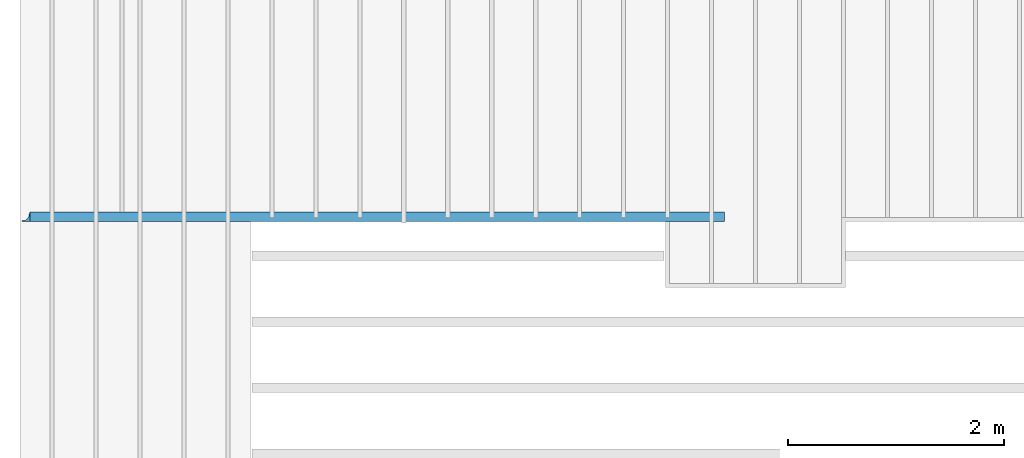
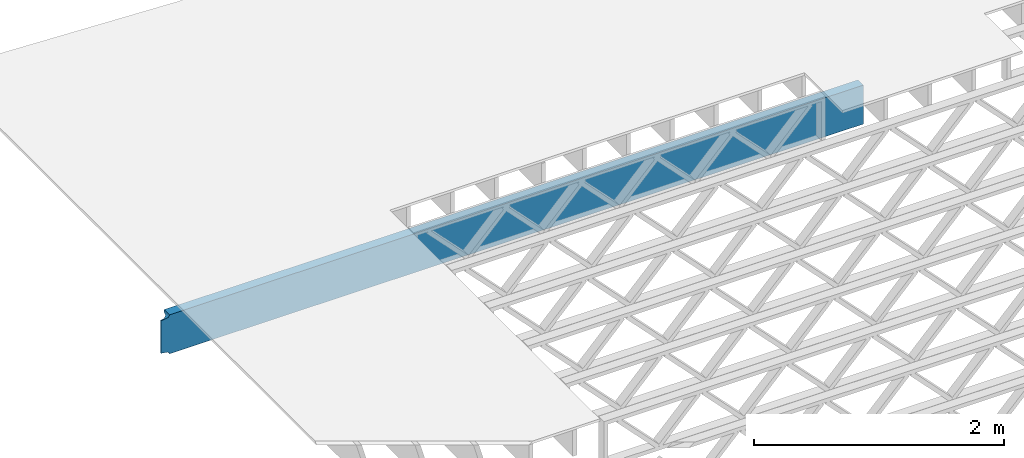
# One storey, part 13 of 23: 1 beam.
"""IFC4 building model written with IfcOpenShell, lengths in feet."""

from ifc_helpers import new_model, entity, si_unit, converted_unit, derived_unit, direction, frame, origin, place, context, subcontext, project, spatial, polyline, circle_curve, parameter, trimmed, segment, composite_curve, outline, source, transform, mapped, material, material_profile, profile_set, type_object, type_shapes, element, save


model = new_model("IFC4")

# Units and contexts
model_context = context("Model", 3, precision=0.0001, world=origin(), true_north=direction((6.12303176911189e-17, 1.0)))
body_context = subcontext(model_context, "Body", "Model", "MODEL_VIEW")
ifc_project = project(units=[converted_unit("LENGTHUNIT", "FOOT", entity("IfcRatioMeasure", 0.3048), si_unit("LENGTHUNIT", "METRE"), dimensions=[1, 0, 0, 0, 0, 0, 0]), converted_unit("AREAUNIT", "SQUARE FOOT", entity("IfcRatioMeasure", 0.09290304), si_unit("AREAUNIT", "SQUARE_METRE"), dimensions=[2, 0, 0, 0, 0, 0, 0]), converted_unit("VOLUMEUNIT", "CUBIC FOOT", entity("IfcRatioMeasure", 0.028316846592), si_unit("VOLUMEUNIT", "CUBIC_METRE"), dimensions=[3, 0, 0, 0, 0, 0, 0]), converted_unit("PLANEANGLEUNIT", "DEGREE", entity("IfcRatioMeasure", 0.0174532925199433), si_unit("PLANEANGLEUNIT", "RADIAN"), dimensions=[0, 0, 0, 0, 0, 0, 0]), si_unit("MASSUNIT", "GRAM", prefix="KILO"), derived_unit("MASSDENSITYUNIT", [(si_unit("MASSUNIT", "GRAM", prefix="KILO"), 1), (si_unit("LENGTHUNIT", "METRE"), -3)]), derived_unit("MOMENTOFINERTIAUNIT", [(si_unit("LENGTHUNIT", "METRE"), 4)]), si_unit("TIMEUNIT", "SECOND"), si_unit("FREQUENCYUNIT", "HERTZ"), si_unit("THERMODYNAMICTEMPERATUREUNIT", "DEGREE_CELSIUS"), derived_unit("THERMALTRANSMITTANCEUNIT", [(si_unit("MASSUNIT", "GRAM", prefix="KILO"), 1), (si_unit("THERMODYNAMICTEMPERATUREUNIT", "KELVIN"), -1), (si_unit("TIMEUNIT", "SECOND"), -3)]), derived_unit("VOLUMETRICFLOWRATEUNIT", [(si_unit("LENGTHUNIT", "METRE"), 3), (si_unit("TIMEUNIT", "SECOND"), -1)]), si_unit("ELECTRICCURRENTUNIT", "AMPERE"), si_unit("ELECTRICVOLTAGEUNIT", "VOLT"), si_unit("POWERUNIT", "WATT"), si_unit("FORCEUNIT", "NEWTON"), si_unit("ILLUMINANCEUNIT", "LUX"), si_unit("LUMINOUSFLUXUNIT", "LUMEN"), si_unit("LUMINOUSINTENSITYUNIT", "CANDELA"), derived_unit("USERDEFINED", [(si_unit("MASSUNIT", "GRAM", prefix="KILO"), -1), (si_unit("LENGTHUNIT", "METRE"), -2), (si_unit("TIMEUNIT", "SECOND"), 3), (si_unit("LUMINOUSFLUXUNIT", "LUMEN"), 1)]), derived_unit("LINEARVELOCITYUNIT", [(si_unit("LENGTHUNIT", "METRE"), 1), (si_unit("TIMEUNIT", "SECOND"), -1)]), si_unit("PRESSUREUNIT", "PASCAL"), derived_unit("USERDEFINED", [(si_unit("LENGTHUNIT", "METRE"), -2), (si_unit("MASSUNIT", "GRAM", prefix="KILO"), 1), (si_unit("TIMEUNIT", "SECOND"), -2)]), derived_unit("LINEARFORCEUNIT", [(si_unit("MASSUNIT", "GRAM", prefix="KILO"), 1), (si_unit("LENGTHUNIT", "METRE"), 1), (si_unit("TIMEUNIT", "SECOND"), -2), (si_unit("LENGTHUNIT", "METRE"), -1)]), derived_unit("PLANARFORCEUNIT", [(si_unit("MASSUNIT", "GRAM", prefix="KILO"), 1), (si_unit("LENGTHUNIT", "METRE"), 1), (si_unit("TIMEUNIT", "SECOND"), -2), (si_unit("LENGTHUNIT", "METRE"), -2)])], contexts=[model_context])

# Site, building, storey
site_placement = place(None, origin())
site = spatial("IfcSite", under=ifc_project, at=site_placement, CompositionType="ELEMENT")
building_placement = place(site_placement, origin())
building = spatial("IfcBuilding", under=site, at=building_placement, CompositionType="ELEMENT")
storey_placement = place(building_placement, frame((0.0, 0.0, 10.8020833333333)))
storey = spatial("IfcBuildingStorey", under=building, at=storey_placement, Name="2ND FLOOR", CompositionType="ELEMENT", Elevation=10.8020833333333)

# Beam
ifc_material = material(Name="STEEL C CHANNEL - HDG - SEE STRUCT", Category="Materials")
ifc_material_profile = material_profile(ifc_material, outline(composite_curve([segment(polyline([(0.0323333333333348, -0.539816380436459, 0.0), (0.0323333333333354, 0.539816380436431, 0.0)]), True, "CONTINUOUS"), segment(polyline([(0.0323333333333354, 0.539816380436431, 0.0), (-0.16349999999999, 0.570833333333319, 0.0)]), True, "CONTINUOUS"), segment(trimmed(circle_curve(frame((-0.16349999999999, 0.624999999999984, 0.0), z_axis=(0.0, 0.0, -1.0), x_axis=(-1.0, 0.0, 0.0)), 0.0541666666666667), [parameter(270.0)], [parameter(359.999999999994)], True, "PARAMETER"), True, "CONTINUOUS"), segment(polyline([(-0.217666666666665, 0.624999999999979, 0.0), (0.0656666666666953, 0.624999999999982, 0.0)]), True, "CONTINUOUS"), segment(polyline([(0.0656666666666953, 0.624999999999982, 0.0), (0.0656666666666946, -0.625000000000018, 0.0)]), True, "CONTINUOUS"), segment(polyline([(0.0656666666666946, -0.625000000000018, 0.0), (-0.217666666666665, -0.625000000000018, 0.0)]), True, "CONTINUOUS"), segment(trimmed(circle_curve(frame((-0.163499999999991, -0.625000000000016, 0.0), z_axis=(0.0, 0.0, -1.0), x_axis=(-1.0, 0.0, 0.0)), 0.0541666666666667), [parameter(-2.7988881196879e-12)], [parameter(90.0000000000004)], True, "PARAMETER"), True, "CONTINUOUS"), segment(polyline([(-0.163499999999991, -0.570833333333349, 0.0), (0.0323333333333348, -0.539816380436459, 0.0)]), True, "CONTINUOUS")], self_intersect=False), kind="CURVE"), Name="C15x33.9, TYP.")
ifc_profile_set = profile_set([ifc_material_profile], Name="C15x33.9, TYP.")
beam_type = type_object("IfcBeamType", Name="C-Channel:C15x33.9, TYP.", PredefinedType="BEAM", material=ifc_profile_set)
cartesian_point_1 = entity("IfcCartesianPoint", [21.3125000000427, 0.0, 0.00523383279505651])
vertex_point_1 = entity("IfcVertexPoint", cartesian_point_1)
cartesian_point_2 = entity("IfcCartesianPoint", [21.3125000000427, 0.28333333333353, 0.00523383279505474])
vertex_point_2 = entity("IfcVertexPoint", cartesian_point_2)
ifc_direction_1 = entity("IfcDirection", [0.0, 1.0, 0.0])
edge_curve_1 = entity("IfcEdgeCurve", vertex_point_1, vertex_point_2, entity("IfcTrimmedCurve", entity("IfcLine", cartesian_point_1, entity("IfcVector", ifc_direction_1, 1.0)), [cartesian_point_1], [cartesian_point_2], True, "CARTESIAN"), True)
cartesian_point_3 = entity("IfcCartesianPoint", [21.3125000000427, 0.229166666666856, 0.0594004994617254])
vertex_point_3 = entity("IfcVertexPoint", cartesian_point_3)
ifc_direction_2 = entity("IfcDirection", [1.0, 0.0, 0.0])
edge_curve_2 = entity("IfcEdgeCurve", vertex_point_2, vertex_point_3, entity("IfcTrimmedCurve", entity("IfcCircle", entity("IfcAxis2Placement3D", entity("IfcCartesianPoint", [21.3125000000427, 0.229166666666742, 0.00523383279505829]), ifc_direction_2, ifc_direction_1), 0.0541666666666667), [cartesian_point_2], [cartesian_point_3], True, "CARTESIAN"), True)
cartesian_point_4 = entity("IfcCartesianPoint", [21.3125000000427, 0.0333333333335304, 0.090417452358615])
vertex_point_4 = entity("IfcVertexPoint", cartesian_point_4)
edge_curve_3 = entity("IfcEdgeCurve", vertex_point_3, vertex_point_4, entity("IfcTrimmedCurve", entity("IfcLine", cartesian_point_3, entity("IfcVector", entity("IfcDirection", [0.0, -0.987688340595136, 0.156434465040243]), 1.0)), [cartesian_point_3], [cartesian_point_4], True, "CARTESIAN"), True)
cartesian_point_5 = entity("IfcCartesianPoint", [21.3125000000427, 0.0333333333335304, 1.17005021323151])
vertex_point_5 = entity("IfcVertexPoint", cartesian_point_5)
ifc_direction_3 = entity("IfcDirection", [0.0, 0.0, -1.0])
edge_curve_4 = entity("IfcEdgeCurve", vertex_point_5, vertex_point_4, entity("IfcTrimmedCurve", entity("IfcLine", cartesian_point_4, entity("IfcVector", ifc_direction_3, 1.0)), [cartesian_point_5], [cartesian_point_4], True, "CARTESIAN"), True)
cartesian_point_6 = entity("IfcCartesianPoint", [21.3125000000427, 0.229166666666856, 1.20106716612839])
vertex_point_6 = entity("IfcVertexPoint", cartesian_point_6)
edge_curve_5 = entity("IfcEdgeCurve", vertex_point_5, vertex_point_6, entity("IfcTrimmedCurve", entity("IfcLine", cartesian_point_5, entity("IfcVector", entity("IfcDirection", [0.0, 0.987688340595139, 0.156434465040225]), 1.0)), [cartesian_point_5], [cartesian_point_6], True, "CARTESIAN"), True)
cartesian_point_7 = entity("IfcCartesianPoint", [21.3125000000427, 0.28333333333353, 1.25523383279505])
vertex_point_7 = entity("IfcVertexPoint", cartesian_point_7)
edge_curve_6 = entity("IfcEdgeCurve", vertex_point_6, vertex_point_7, entity("IfcTrimmedCurve", entity("IfcCircle", entity("IfcAxis2Placement3D", entity("IfcCartesianPoint", [21.3125000000427, 0.229166666666742, 1.25523383279506]), ifc_direction_2, ifc_direction_1), 0.0541666666666667), [cartesian_point_6], [cartesian_point_7], True, "CARTESIAN"), True)
cartesian_point_8 = entity("IfcCartesianPoint", [21.3125000000427, 0.0, 1.25523383279506])
vertex_point_8 = entity("IfcVertexPoint", cartesian_point_8)
ifc_direction_4 = entity("IfcDirection", [0.0, -1.0, 0.0])
edge_curve_7 = entity("IfcEdgeCurve", vertex_point_7, vertex_point_8, entity("IfcTrimmedCurve", entity("IfcLine", cartesian_point_7, entity("IfcVector", ifc_direction_4, 1.0)), [cartesian_point_7], [cartesian_point_8], True, "CARTESIAN"), True)
edge_curve_8 = entity("IfcEdgeCurve", vertex_point_8, vertex_point_1, entity("IfcTrimmedCurve", entity("IfcLine", cartesian_point_8, entity("IfcVector", ifc_direction_3, 1.0)), [cartesian_point_8], [cartesian_point_1], True, "CARTESIAN"), True)
ifc_direction_5 = entity("IfcDirection", [0.0, 0.0, 1.0])
cartesian_point_9 = entity("IfcCartesianPoint", [0.11234277545401, 0.033333333333303, 0.0904174523585581])
vertex_point_9 = entity("IfcVertexPoint", cartesian_point_9)
ifc_direction_6 = entity("IfcDirection", [-1.0, 0.0, 0.0])
edge_curve_9 = entity("IfcEdgeCurve", vertex_point_4, vertex_point_9, entity("IfcTrimmedCurve", entity("IfcLine", cartesian_point_9, entity("IfcVector", ifc_direction_6, 1.0)), [cartesian_point_4], [cartesian_point_9], True, "CARTESIAN"), True)
cartesian_point_10 = entity("IfcCartesianPoint", [0.0, 0.033333333333303, 0.108210799973349])
vertex_point_10 = entity("IfcVertexPoint", cartesian_point_10)
edge_curve_10 = entity("IfcEdgeCurve", vertex_point_9, vertex_point_10, entity("IfcTrimmedCurve", entity("IfcLine", cartesian_point_9, entity("IfcVector", entity("IfcDirection", [-0.987688340595134, 0.0, 0.156434465040255]), 1.0)), [cartesian_point_9], [cartesian_point_10], True, "CARTESIAN"), True)
cartesian_point_11 = entity("IfcCartesianPoint", [0.0, 0.033333333333303, 1.15225686561857])
vertex_point_11 = entity("IfcVertexPoint", cartesian_point_11)
edge_curve_11 = entity("IfcEdgeCurve", vertex_point_10, vertex_point_11, entity("IfcTrimmedCurve", entity("IfcLine", cartesian_point_10, entity("IfcVector", ifc_direction_5, 1.0)), [cartesian_point_10], [cartesian_point_11], True, "CARTESIAN"), True)
cartesian_point_12 = entity("IfcCartesianPoint", [0.112342775441903, 0.033333333333303, 1.17005021323144])
vertex_point_12 = entity("IfcVertexPoint", cartesian_point_12)
edge_curve_12 = entity("IfcEdgeCurve", vertex_point_11, vertex_point_12, entity("IfcTrimmedCurve", entity("IfcLine", cartesian_point_11, entity("IfcVector", entity("IfcDirection", [0.987688340595135, 0.0, 0.156434465040249]), 1.0)), [cartesian_point_11], [cartesian_point_12], True, "CARTESIAN"), True)
edge_curve_13 = entity("IfcEdgeCurve", vertex_point_12, vertex_point_5, entity("IfcTrimmedCurve", entity("IfcLine", cartesian_point_12, entity("IfcVector", ifc_direction_2, 1.0)), [cartesian_point_12], [cartesian_point_5], True, "CARTESIAN"), True)
cartesian_point_13 = entity("IfcCartesianPoint", [0.250000000000057, 0.283333333333303, 1.255233832795])
vertex_point_13 = entity("IfcVertexPoint", cartesian_point_13)
edge_curve_14 = entity("IfcEdgeCurve", vertex_point_7, vertex_point_13, entity("IfcTrimmedCurve", entity("IfcLine", cartesian_point_13, entity("IfcVector", ifc_direction_6, 1.0)), [cartesian_point_7], [cartesian_point_13], True, "CARTESIAN"), True)
cartesian_point_14 = entity("IfcCartesianPoint", [0.250000000000057, 0.0, 1.255233832795])
vertex_point_14 = entity("IfcVertexPoint", cartesian_point_14)
edge_curve_15 = entity("IfcEdgeCurve", vertex_point_13, vertex_point_14, entity("IfcTrimmedCurve", entity("IfcLine", cartesian_point_13, entity("IfcVector", ifc_direction_4, 1.0)), [cartesian_point_13], [cartesian_point_14], True, "CARTESIAN"), True)
edge_curve_16 = entity("IfcEdgeCurve", vertex_point_14, vertex_point_8, entity("IfcTrimmedCurve", entity("IfcLine", cartesian_point_14, entity("IfcVector", ifc_direction_2, 1.0)), [cartesian_point_14], [cartesian_point_8], True, "CARTESIAN"), True)
cartesian_point_15 = entity("IfcCartesianPoint", [0.226874581657341, 0.229166666666629, 1.20106716612834])
vertex_point_15 = entity("IfcVertexPoint", cartesian_point_15)
edge_curve_17 = entity("IfcEdgeCurve", vertex_point_6, vertex_point_15, entity("IfcTrimmedCurve", entity("IfcLine", cartesian_point_15, entity("IfcVector", ifc_direction_6, 1.0)), [cartesian_point_6], [cartesian_point_15], True, "CARTESIAN"), True)
edge_curve_18 = entity("IfcEdgeCurve", vertex_point_15, vertex_point_13, entity("IfcBSplineCurveWithKnots", 3, [cartesian_point_15, entity("IfcCartesianPoint", [0.22693213851403, 0.231302908058751, 1.20106716612834]), entity("IfcCartesianPoint", [0.227159053150444, 0.234477877691006, 1.20125696162021]), entity("IfcCartesianPoint", [0.227748739977926, 0.238609771260144, 1.20186628027352]), entity("IfcCartesianPoint", [0.228322621536392, 0.24164938934905, 1.20249496685218]), entity("IfcCartesianPoint", [0.229075921738684, 0.2446171853328, 1.20328751433331]), entity("IfcCartesianPoint", [0.230000215547932, 0.247505652234963, 1.2042361678286]), entity("IfcCartesianPoint", [0.230853749669848, 0.249844679929765, 1.2051519255893]), entity("IfcCartesianPoint", [0.231562022758681, 0.251673003801898, 1.20595666968713]), entity("IfcCartesianPoint", [0.232093273511907, 0.25302337235928, 1.20659612777582]), entity("IfcCartesianPoint", [0.232638911129641, 0.254348721252654, 1.20726902069318]), entity("IfcCartesianPoint", [0.233406806167864, 0.256078909363055, 1.20820780539494]), entity("IfcCartesianPoint", [0.234414161226596, 0.258177734396668, 1.20946014153352]), entity("IfcCartesianPoint", [0.235663533184322, 0.260599660323692, 1.21108819175386]), entity("IfcCartesianPoint", [0.236889305293914, 0.262936815118678, 1.21284912635198]), entity("IfcCartesianPoint", [0.238114491072793, 0.265174348463802, 1.21473306105842]), entity("IfcCartesianPoint", [0.239370454786979, 0.267298458689197, 1.21672641619436]), entity("IfcCartesianPoint", [0.240608524568586, 0.269317422636163, 1.21883594076784]), entity("IfcCartesianPoint", [0.241783811235337, 0.271234781187331, 1.22106933292456]), entity("IfcCartesianPoint", [0.242916330994944, 0.273039937208068, 1.22342029305287]), entity("IfcCartesianPoint", [0.244030003635544, 0.27471923829296, 1.22587475466331]), entity("IfcCartesianPoint", [0.245081974156847, 0.276271926597474, 1.22843576465876]), entity("IfcCartesianPoint", [0.246032147772439, 0.277692860999878, 1.23110270219596]), entity("IfcCartesianPoint", [0.246896163628776, 0.278975433597566, 1.23387382034537]), entity("IfcCartesianPoint", [0.247966646713394, 0.280486340282323, 1.23769151330883]), entity("IfcCartesianPoint", [0.249457596096079, 0.282575050448258, 1.24465067540511]), entity("IfcCartesianPoint", [0.249960713518931, 0.283333333333189, 1.25096768477873]), cartesian_point_13], "UNSPECIFIED", False, "UNKNOWN", [4, 1, 1, 1, 1, 1, 1, 1, 1, 1, 1, 1, 1, 1, 1, 1, 1, 1, 1, 1, 1, 1, 1, 1, 1, 4], [0.0, 0.0714285714285714, 0.107142857142857, 0.142857142857143, 0.178571428571429, 0.214285714285714, 0.25, 0.267857142857143, 0.285714285714286, 0.303571428571429, 0.321428571428571, 0.357142857142857, 0.392857142857143, 0.428571428571429, 0.464285714285714, 0.5, 0.535714285714286, 0.571428571428571, 0.607142857142857, 0.642857142857143, 0.678571428571429, 0.714285714285714, 0.75, 0.785714285714286, 0.857142857142857, 1.0], "UNSPECIFIED"), True)
cartesian_point_16 = entity("IfcCartesianPoint", [0.176771770254561, 0.0977623281457909, 1.1802547635155])
vertex_point_16 = entity("IfcVertexPoint", cartesian_point_16)
edge_curve_19 = entity("IfcEdgeCurve", vertex_point_12, vertex_point_16, entity("IfcTrimmedCurve", entity("IfcLine", cartesian_point_12, entity("IfcVector", entity("IfcDirection", [0.702713511302185, 0.702713511300945, 0.111298886195909]), 1.0)), [cartesian_point_12], [cartesian_point_16], True, "CARTESIAN"), True)
edge_curve_20 = entity("IfcEdgeCurve", vertex_point_16, vertex_point_15, entity("IfcBSplineCurveWithKnots", 3, [cartesian_point_16, entity("IfcCartesianPoint", [0.179424255432082, 0.0981629910289712, 1.18031822228201]), entity("IfcCartesianPoint", [0.184688685076367, 0.100708070964743, 1.18072132334325]), entity("IfcCartesianPoint", [0.192504359595716, 0.109798544471801, 1.18216111290199]), entity("IfcCartesianPoint", [0.200117107609628, 0.124037098296981, 1.18441627828058]), entity("IfcCartesianPoint", [0.207451661180642, 0.143273387306976, 1.1874630071493]), entity("IfcCartesianPoint", [0.214421685196612, 0.167280980928012, 1.19126543642851]), entity("IfcCartesianPoint", [0.22095719275444, 0.195829265308021, 1.19578704047226]), entity("IfcCartesianPoint", [0.224957810481897, 0.217583568723057, 1.19923258364332]), cartesian_point_15], "UNSPECIFIED", False, "UNKNOWN", [4, 1, 1, 1, 1, 1, 1, 4], [0.0, 0.142857142857143, 0.285714285714286, 0.428571428571429, 0.571428571428571, 0.714285714285714, 0.857142857142857, 1.0], "UNSPECIFIED"), True)
cartesian_point_17 = entity("IfcCartesianPoint", [0.226874581659331, 0.229166666666515, 0.0594004994616899])
vertex_point_17 = entity("IfcVertexPoint", cartesian_point_17)
edge_curve_21 = entity("IfcEdgeCurve", vertex_point_3, vertex_point_17, entity("IfcTrimmedCurve", entity("IfcLine", cartesian_point_17, entity("IfcVector", ifc_direction_6, 1.0)), [cartesian_point_3], [cartesian_point_17], True, "CARTESIAN"), True)
cartesian_point_18 = entity("IfcCartesianPoint", [0.176771770254391, 0.0977623281336264, 0.0802129020764379])
vertex_point_18 = entity("IfcVertexPoint", cartesian_point_18)
edge_curve_22 = entity("IfcEdgeCurve", vertex_point_17, vertex_point_18, entity("IfcBSplineCurveWithKnots", 3, [cartesian_point_17, entity("IfcCartesianPoint", [0.224957810483943, 0.217583568722034, 0.061235081946851]), entity("IfcCartesianPoint", [0.220957192756373, 0.19582926530461, 0.0646806251182319]), entity("IfcCartesianPoint", [0.214421685198261, 0.167280980922328, 0.0692022291623715]), entity("IfcCartesianPoint", [0.20745166118212, 0.143273387298905, 0.0730046584419508]), entity("IfcCartesianPoint", [0.200117107610993, 0.124037098287886, 0.0760513873109492]), entity("IfcCartesianPoint", [0.192504359596455, 0.109798544461, 0.0783065526897548]), entity("IfcCartesianPoint", [0.184688685076878, 0.100708070953374, 0.079746342248626]), entity("IfcCartesianPoint", [0.179424255432195, 0.0981629910170341, 0.080149443309903]), cartesian_point_18], "UNSPECIFIED", False, "UNKNOWN", [4, 1, 1, 1, 1, 1, 1, 4], [0.0, 0.142857142857143, 0.285714285714286, 0.428571428571429, 0.571428571428571, 0.714285714285714, 0.857142857142857, 1.0], "UNSPECIFIED"), True)
edge_curve_23 = entity("IfcEdgeCurve", vertex_point_18, vertex_point_9, entity("IfcTrimmedCurve", entity("IfcLine", cartesian_point_18, entity("IfcVector", entity("IfcDirection", [-0.702713511301559, -0.702713511301559, 0.111298886195993]), 1.0)), [cartesian_point_18], [cartesian_point_9], True, "CARTESIAN"), True)
cartesian_point_19 = entity("IfcCartesianPoint", [0.250000000000057, 0.283333333333303, 0.00523383279499967])
vertex_point_19 = entity("IfcVertexPoint", cartesian_point_19)
edge_curve_24 = entity("IfcEdgeCurve", vertex_point_2, vertex_point_19, entity("IfcTrimmedCurve", entity("IfcLine", cartesian_point_19, entity("IfcVector", ifc_direction_6, 1.0)), [cartesian_point_2], [cartesian_point_19], True, "CARTESIAN"), True)
edge_curve_25 = entity("IfcEdgeCurve", vertex_point_19, vertex_point_17, entity("IfcBSplineCurveWithKnots", 3, [cartesian_point_19, entity("IfcCartesianPoint", [0.249961591003341, 0.283333333333303, 0.00949177953389757]), entity("IfcCartesianPoint", [0.249459813805686, 0.282578090780703, 0.0157997514910537]), entity("IfcCartesianPoint", [0.24797096399783, 0.280492852797693, 0.0227570676820807]), entity("IfcCartesianPoint", [0.246901671232763, 0.278983413269998, 0.0265752239741825]), entity("IfcCartesianPoint", [0.246038387513408, 0.27770195599453, 0.0293466548115955]), entity("IfcCartesianPoint", [0.245088765357139, 0.276282116651942, 0.0320139817367924]), entity("IfcCartesianPoint", [0.244037249299254, 0.274730285687497, 0.0345757746752398]), entity("IfcCartesianPoint", [0.242923938293643, 0.273051718346437, 0.0370311269382171]), entity("IfcCartesianPoint", [0.241791691002675, 0.2712473027035, 0.0393829154086394]), entity("IfcCartesianPoint", [0.240616672836438, 0.269330623299311, 0.0416171588294922]), entity("IfcCartesianPoint", [0.23937842891786, 0.267312309505769, 0.0437275476103629]), entity("IfcCartesianPoint", [0.238123503086399, 0.265188500133149, 0.0457219963912969]), entity("IfcCartesianPoint", [0.237099425803365, 0.263325362339401, 0.0472918804028328]), entity("IfcCartesianPoint", [0.236288696335009, 0.261782638817294, 0.0484881828371684]), entity("IfcCartesianPoint", [0.235461340833297, 0.260212995068969, 0.0496388763908904]), entity("IfcCartesianPoint", [0.234423418720041, 0.258194892409051, 0.0509966617009656]), entity("IfcCartesianPoint", [0.23341515692357, 0.256097365885012, 0.0522492796322851]), entity("IfcCartesianPoint", [0.232647242748101, 0.25436779979168, 0.0531886235364247]), entity("IfcCartesianPoint", [0.232101391795538, 0.253042778305257, 0.0538620139134967]), entity("IfcCartesianPoint", [0.231569855345697, 0.251692685307603, 0.0545020014489204]), entity("IfcCartesianPoint", [0.230861078653675, 0.249864823890675, 0.055307415021641]), entity("IfcCartesianPoint", [0.230006751834424, 0.247526266886894, 0.0562240814465511]), entity("IfcCartesianPoint", [0.229081365873753, 0.244637701444617, 0.0571740662148539]), entity("IfcCartesianPoint", [0.228327001834202, 0.241668406546182, 0.0579682457738642]), entity("IfcCartesianPoint", [0.227752105112927, 0.238625753575548, 0.0585986293679959]), entity("IfcCartesianPoint", [0.227160977067115, 0.234488383867188, 0.0592098794855822]), entity("IfcCartesianPoint", [0.226932925800497, 0.231307534122607, 0.0594004994616757]), cartesian_point_17], "UNSPECIFIED", False, "UNKNOWN", [4, 1, 1, 1, 1, 1, 1, 1, 1, 1, 1, 1, 1, 1, 1, 1, 1, 1, 1, 1, 1, 1, 1, 1, 1, 1, 4], [0.0, 0.142857142857143, 0.214285714285714, 0.25, 0.285714285714286, 0.321428571428571, 0.357142857142857, 0.392857142857143, 0.428571428571429, 0.464285714285714, 0.5, 0.535714285714286, 0.571428571428571, 0.589285714285714, 0.607142857142857, 0.642857142857143, 0.678571428571429, 0.696428571428571, 0.714285714285714, 0.732142857142857, 0.75, 0.785714285714286, 0.821428571428571, 0.857142857142857, 0.892857142857143, 0.928571428571429, 1.0], "UNSPECIFIED"), True)
cartesian_point_20 = entity("IfcCartesianPoint", [0.250000000000057, 0.0, 0.00523383279500145])
vertex_point_20 = entity("IfcVertexPoint", cartesian_point_20)
edge_curve_26 = entity("IfcEdgeCurve", vertex_point_1, vertex_point_20, entity("IfcTrimmedCurve", entity("IfcLine", cartesian_point_20, entity("IfcVector", ifc_direction_6, 1.0)), [cartesian_point_1], [cartesian_point_20], True, "CARTESIAN"), True)
edge_curve_27 = entity("IfcEdgeCurve", vertex_point_20, vertex_point_19, entity("IfcTrimmedCurve", entity("IfcLine", cartesian_point_20, entity("IfcVector", ifc_direction_1, 1.0)), [cartesian_point_20], [cartesian_point_19], True, "CARTESIAN"), True)
cartesian_point_21 = entity("IfcCartesianPoint", [0.176771770254391, 0.0, 1.18025476351548])
vertex_point_21 = entity("IfcVertexPoint", cartesian_point_21)
edge_curve_28 = entity("IfcEdgeCurve", vertex_point_14, vertex_point_21, entity("IfcTrimmedCurve", entity("IfcCircle", entity("IfcAxis2Placement3D", entity("IfcCartesianPoint", [0.175000000000068, 0.0, 1.25523383279595]), ifc_direction_1, ifc_direction_2), 0.075), [cartesian_point_14], [cartesian_point_21], True, "CARTESIAN"), True)
cartesian_point_22 = entity("IfcCartesianPoint", [0.0, 0.0, 1.15225686561857])
vertex_point_22 = entity("IfcVertexPoint", cartesian_point_22)
edge_curve_29 = entity("IfcEdgeCurve", vertex_point_21, vertex_point_22, entity("IfcTrimmedCurve", entity("IfcLine", cartesian_point_21, entity("IfcVector", entity("IfcDirection", [-0.987688340595138, 0.0, -0.156434465040229]), 1.0)), [cartesian_point_21], [cartesian_point_22], True, "CARTESIAN"), True)
cartesian_point_23 = entity("IfcCartesianPoint", [0.0, 0.0, 0.108210799973339])
vertex_point_23 = entity("IfcVertexPoint", cartesian_point_23)
edge_curve_30 = entity("IfcEdgeCurve", vertex_point_22, vertex_point_23, entity("IfcTrimmedCurve", entity("IfcLine", cartesian_point_22, entity("IfcVector", ifc_direction_3, 1.0)), [cartesian_point_22], [cartesian_point_23], True, "CARTESIAN"), True)
cartesian_point_24 = entity("IfcCartesianPoint", [0.176771770254391, 0.0, 0.0802129020764255])
vertex_point_24 = entity("IfcVertexPoint", cartesian_point_24)
edge_curve_31 = entity("IfcEdgeCurve", vertex_point_23, vertex_point_24, entity("IfcTrimmedCurve", entity("IfcLine", cartesian_point_23, entity("IfcVector", entity("IfcDirection", [0.987688340595134, 0.0, -0.156434465040257]), 1.0)), [cartesian_point_23], [cartesian_point_24], True, "CARTESIAN"), True)
edge_curve_32 = entity("IfcEdgeCurve", vertex_point_24, vertex_point_20, entity("IfcTrimmedCurve", entity("IfcCircle", entity("IfcAxis2Placement3D", entity("IfcCartesianPoint", [0.175000000000068, 0.0, 0.00523383279595357]), ifc_direction_1, ifc_direction_2), 0.075), [cartesian_point_24], [cartesian_point_20], True, "CARTESIAN"), True)
edge_curve_33 = entity("IfcEdgeCurve", vertex_point_24, vertex_point_18, entity("IfcTrimmedCurve", entity("IfcLine", cartesian_point_18, entity("IfcVector", ifc_direction_1, 1.0)), [cartesian_point_24], [cartesian_point_18], True, "CARTESIAN"), True)
edge_curve_34 = entity("IfcEdgeCurve", vertex_point_23, vertex_point_10, entity("IfcTrimmedCurve", entity("IfcLine", cartesian_point_10, entity("IfcVector", ifc_direction_1, 1.0)), [cartesian_point_23], [cartesian_point_10], True, "CARTESIAN"), True)
edge_curve_35 = entity("IfcEdgeCurve", vertex_point_22, vertex_point_11, entity("IfcTrimmedCurve", entity("IfcLine", cartesian_point_11, entity("IfcVector", ifc_direction_1, 1.0)), [cartesian_point_22], [cartesian_point_11], True, "CARTESIAN"), True)
edge_curve_36 = entity("IfcEdgeCurve", vertex_point_21, vertex_point_16, entity("IfcTrimmedCurve", entity("IfcLine", cartesian_point_16, entity("IfcVector", ifc_direction_1, 1.0)), [cartesian_point_21], [cartesian_point_16], True, "CARTESIAN"), True)
shared_shape = source(origin(), body_context, "Body", "AdvancedBrep", [
    entity("IfcAdvancedBrep", entity("IfcClosedShell", [entity("IfcAdvancedFace", [entity("IfcFaceOuterBound", entity("IfcEdgeLoop", [entity("IfcOrientedEdge", None, None, edge_curve_1, True), entity("IfcOrientedEdge", None, None, edge_curve_2, True), entity("IfcOrientedEdge", None, None, edge_curve_3, True), entity("IfcOrientedEdge", None, None, edge_curve_4, False), entity("IfcOrientedEdge", None, None, edge_curve_5, True), entity("IfcOrientedEdge", None, None, edge_curve_6, True), entity("IfcOrientedEdge", None, None, edge_curve_7, True), entity("IfcOrientedEdge", None, None, edge_curve_8, True)]), True)], entity("IfcPlane", entity("IfcAxis2Placement3D", entity("IfcCartesianPoint", [21.3125000000427, 0.0656666666668571, 0.630233832795074]), ifc_direction_2, ifc_direction_5)), True), entity("IfcAdvancedFace", [entity("IfcFaceOuterBound", entity("IfcEdgeLoop", [entity("IfcOrientedEdge", None, None, edge_curve_4, True), entity("IfcOrientedEdge", None, None, edge_curve_9, True), entity("IfcOrientedEdge", None, None, edge_curve_10, True), entity("IfcOrientedEdge", None, None, edge_curve_11, True), entity("IfcOrientedEdge", None, None, edge_curve_12, True), entity("IfcOrientedEdge", None, None, edge_curve_13, True)]), True)], entity("IfcPlane", entity("IfcAxis2Placement3D", entity("IfcCartesianPoint", [-0.29767379518529, 0.033333333333303, 1.17005021323145]), ifc_direction_1, ifc_direction_2)), True), entity("IfcAdvancedFace", [entity("IfcFaceOuterBound", entity("IfcEdgeLoop", [entity("IfcOrientedEdge", None, None, edge_curve_7, False), entity("IfcOrientedEdge", None, None, edge_curve_14, True), entity("IfcOrientedEdge", None, None, edge_curve_15, True), entity("IfcOrientedEdge", None, None, edge_curve_16, True)]), True)], entity("IfcPlane", entity("IfcAxis2Placement3D", entity("IfcCartesianPoint", [-0.29767379518529, 0.0, 1.255233832795]), ifc_direction_5, ifc_direction_2)), True), entity("IfcAdvancedFace", [entity("IfcFaceOuterBound", entity("IfcEdgeLoop", [entity("IfcOrientedEdge", None, None, edge_curve_6, False), entity("IfcOrientedEdge", None, None, edge_curve_17, True), entity("IfcOrientedEdge", None, None, edge_curve_18, True), entity("IfcOrientedEdge", None, None, edge_curve_14, False)]), True)], entity("IfcCylindricalSurface", entity("IfcAxis2Placement3D", entity("IfcCartesianPoint", [-0.29767379518529, 0.229166666666629, 1.255233832795]), ifc_direction_6, ifc_direction_1), 0.0541666666666667), True), entity("IfcAdvancedFace", [entity("IfcFaceOuterBound", entity("IfcEdgeLoop", [entity("IfcOrientedEdge", None, None, edge_curve_5, False), entity("IfcOrientedEdge", None, None, edge_curve_13, False), entity("IfcOrientedEdge", None, None, edge_curve_19, True), entity("IfcOrientedEdge", None, None, edge_curve_20, True), entity("IfcOrientedEdge", None, None, edge_curve_17, False)]), True)], entity("IfcPlane", entity("IfcAxis2Placement3D", entity("IfcCartesianPoint", [-0.29767379518529, 0.229166666666629, 1.20106716612834]), entity("IfcDirection", [0.0, 0.156434465040225, -0.987688340595139]), ifc_direction_2)), True), entity("IfcAdvancedFace", [entity("IfcFaceOuterBound", entity("IfcEdgeLoop", [entity("IfcOrientedEdge", None, None, edge_curve_3, False), entity("IfcOrientedEdge", None, None, edge_curve_21, True), entity("IfcOrientedEdge", None, None, edge_curve_22, True), entity("IfcOrientedEdge", None, None, edge_curve_23, True), entity("IfcOrientedEdge", None, None, edge_curve_9, False)]), True)], entity("IfcPlane", entity("IfcAxis2Placement3D", entity("IfcCartesianPoint", [-0.29767379518529, 0.033333333333303, 0.0904174523585581]), entity("IfcDirection", [0.0, 0.156434465040236, 0.987688340595137]), ifc_direction_2)), True), entity("IfcAdvancedFace", [entity("IfcFaceOuterBound", entity("IfcEdgeLoop", [entity("IfcOrientedEdge", None, None, edge_curve_2, False), entity("IfcOrientedEdge", None, None, edge_curve_24, True), entity("IfcOrientedEdge", None, None, edge_curve_25, True), entity("IfcOrientedEdge", None, None, edge_curve_21, False)]), True)], entity("IfcCylindricalSurface", entity("IfcAxis2Placement3D", entity("IfcCartesianPoint", [-0.29767379518529, 0.229166666666629, 0.00523383279500145]), ifc_direction_6, ifc_direction_1), 0.0541666666666667), True), entity("IfcAdvancedFace", [entity("IfcFaceOuterBound", entity("IfcEdgeLoop", [entity("IfcOrientedEdge", None, None, edge_curve_1, False), entity("IfcOrientedEdge", None, None, edge_curve_26, True), entity("IfcOrientedEdge", None, None, edge_curve_27, True), entity("IfcOrientedEdge", None, None, edge_curve_24, False)]), True)], entity("IfcPlane", entity("IfcAxis2Placement3D", entity("IfcCartesianPoint", [-0.29767379518529, 0.283333333333303, 0.00523383279499967]), ifc_direction_3, ifc_direction_2)), True), entity("IfcAdvancedFace", [entity("IfcFaceOuterBound", entity("IfcEdgeLoop", [entity("IfcOrientedEdge", None, None, edge_curve_8, False), entity("IfcOrientedEdge", None, None, edge_curve_16, False), entity("IfcOrientedEdge", None, None, edge_curve_28, True), entity("IfcOrientedEdge", None, None, edge_curve_29, True), entity("IfcOrientedEdge", None, None, edge_curve_30, True), entity("IfcOrientedEdge", None, None, edge_curve_31, True), entity("IfcOrientedEdge", None, None, edge_curve_32, True), entity("IfcOrientedEdge", None, None, edge_curve_26, False)]), True)], entity("IfcPlane", entity("IfcAxis2Placement3D", entity("IfcCartesianPoint", [-0.29767379518529, 0.0, 0.00523383279499967]), ifc_direction_4, ifc_direction_2)), True), entity("IfcAdvancedFace", [entity("IfcFaceOuterBound", entity("IfcEdgeLoop", [entity("IfcOrientedEdge", None, None, edge_curve_33, True), entity("IfcOrientedEdge", None, None, edge_curve_22, False), entity("IfcOrientedEdge", None, None, edge_curve_25, False), entity("IfcOrientedEdge", None, None, edge_curve_27, False), entity("IfcOrientedEdge", None, None, edge_curve_32, False)]), True)], entity("IfcCylindricalSurface", entity("IfcAxis2Placement3D", entity("IfcCartesianPoint", [0.175000000000068, -0.677507269211674, 0.00523383279595535]), ifc_direction_4, ifc_direction_2), 0.075), False), entity("IfcAdvancedFace", [entity("IfcFaceOuterBound", entity("IfcEdgeLoop", [entity("IfcOrientedEdge", None, None, edge_curve_33, False), entity("IfcOrientedEdge", None, None, edge_curve_31, False), entity("IfcOrientedEdge", None, None, edge_curve_34, True), entity("IfcOrientedEdge", None, None, edge_curve_10, False), entity("IfcOrientedEdge", None, None, edge_curve_23, False)]), True)], entity("IfcPlane", entity("IfcAxis2Placement3D", entity("IfcCartesianPoint", [0.176771770254391, -12.7439571126698, 0.080212902076461]), entity("IfcDirection", [-0.156434465040243, 0.0, -0.987688340595136]), ifc_direction_1)), True), entity("IfcAdvancedFace", [entity("IfcFaceOuterBound", entity("IfcEdgeLoop", [entity("IfcOrientedEdge", None, None, edge_curve_34, False), entity("IfcOrientedEdge", None, None, edge_curve_30, False), entity("IfcOrientedEdge", None, None, edge_curve_35, True), entity("IfcOrientedEdge", None, None, edge_curve_11, False)]), True)], entity("IfcPlane", entity("IfcAxis2Placement3D", entity("IfcCartesianPoint", [0.0, -12.7439571126698, 0.108210799973374]), ifc_direction_6, ifc_direction_1)), True), entity("IfcAdvancedFace", [entity("IfcFaceOuterBound", entity("IfcEdgeLoop", [entity("IfcOrientedEdge", None, None, edge_curve_35, False), entity("IfcOrientedEdge", None, None, edge_curve_29, False), entity("IfcOrientedEdge", None, None, edge_curve_36, True), entity("IfcOrientedEdge", None, None, edge_curve_19, False), entity("IfcOrientedEdge", None, None, edge_curve_12, False)]), True)], entity("IfcPlane", entity("IfcAxis2Placement3D", entity("IfcCartesianPoint", [0.0, -12.7439571126698, 1.15225686561861]), entity("IfcDirection", [-0.156434465040234, 0.0, 0.987688340595137]), ifc_direction_1)), True), entity("IfcAdvancedFace", [entity("IfcFaceOuterBound", entity("IfcEdgeLoop", [entity("IfcOrientedEdge", None, None, edge_curve_36, False), entity("IfcOrientedEdge", None, None, edge_curve_28, False), entity("IfcOrientedEdge", None, None, edge_curve_15, False), entity("IfcOrientedEdge", None, None, edge_curve_18, False), entity("IfcOrientedEdge", None, None, edge_curve_20, False)]), True)], entity("IfcCylindricalSurface", entity("IfcAxis2Placement3D", entity("IfcCartesianPoint", [0.175000000000068, -0.677507269211674, 1.25523383279596]), ifc_direction_4, ifc_direction_2), 0.075), False)])),
])
type_shapes(beam_type, [shared_shape])
beam_placement = place(storey_placement, frame((-272.717327152238, 958.903603004933, -2.45315049946284)))
element("IfcBeam", 1, at=beam_placement, inside=storey, type_object=beam_type, material=ifc_material, Name="C-Channel:C15x33.9, TYP.", ObjectType="C-Channel:C15x33.9, TYP.", PredefinedType="BEAM", context=body_context, shape_type="MappedRepresentation", body=[
    mapped(shared_shape, transform((0.0, 0.0, 0.0), scale=1.0)),
])

save(model, "model.ifc")
